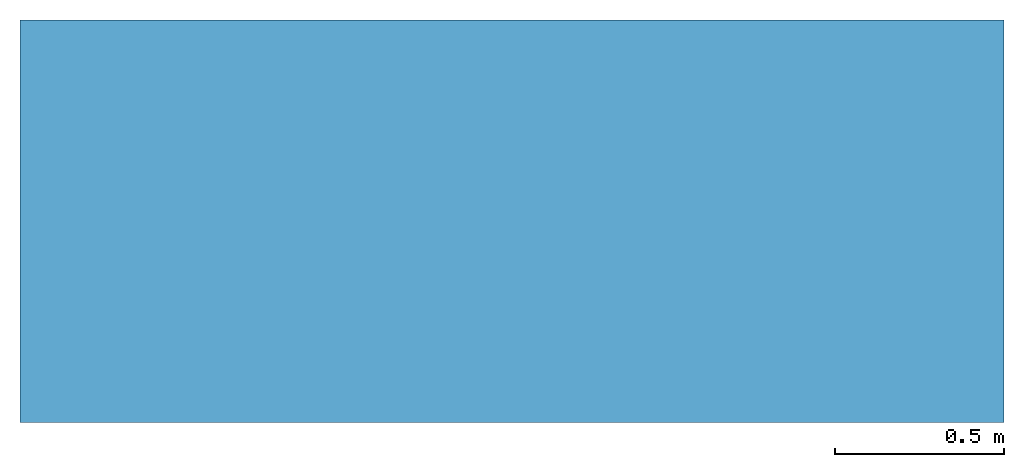
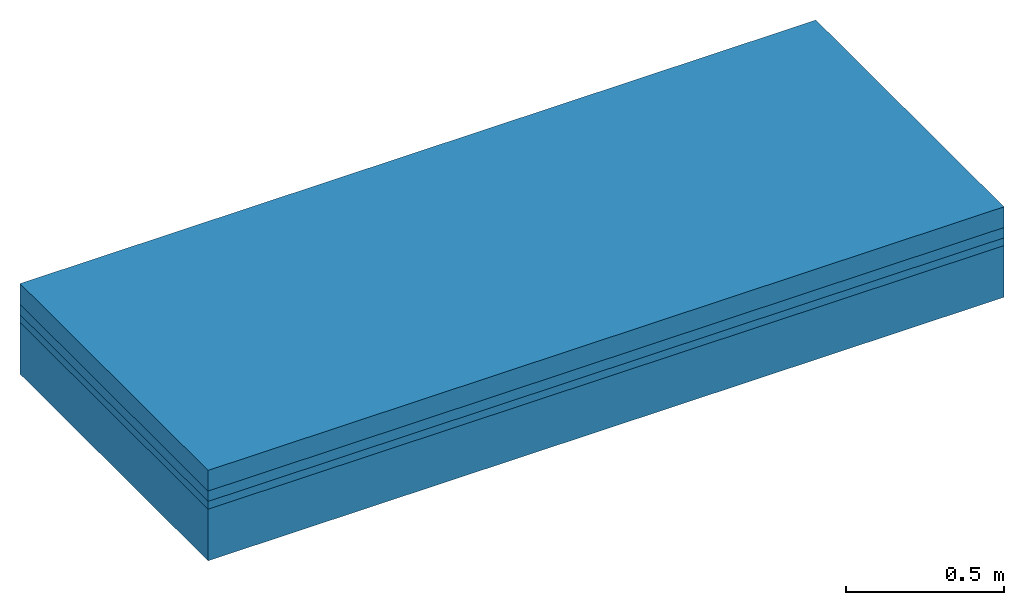
# One storey: 4 building element parts, 1 element without a shape of its own.
"""IFC2X3 building model written with IfcOpenShell, lengths in metres."""

from ifc_helpers import new_model, entity, si_unit, converted_unit, derived_unit, money_unit, direction, frame, origin_with_axes, place, context, subcontext, project, spatial, polyline, outline, extrude, material, type_object, element, aggregate, save


model = new_model("IFC2X3")

# Units and contexts
model_context = context("Model", 3, precision=1e-05, world=origin_with_axes(), true_north=direction((0.309016994375, 0.951056516295)))
body_context = subcontext(model_context, "Body", "Model", "MODEL_VIEW")
ifc_project = project(units=[si_unit("LENGTHUNIT", "METRE"), si_unit("AREAUNIT", "SQUARE_METRE"), si_unit("VOLUMEUNIT", "CUBIC_METRE"), converted_unit("PLANEANGLEUNIT", "DEGREE", entity("IfcPlaneAngleMeasure", 0.0174532925199), si_unit("PLANEANGLEUNIT", "RADIAN"), dimensions=[0, 0, 0, 0, 0, 0, 0]), si_unit("SOLIDANGLEUNIT", "STERADIAN"), money_unit("EUR"), si_unit("TIMEUNIT", "SECOND"), si_unit("MASSUNIT", "GRAM", prefix="KILO"), si_unit("THERMODYNAMICTEMPERATUREUNIT", "DEGREE_CELSIUS"), si_unit("LUMINOUSINTENSITYUNIT", "LUMEN"), si_unit("ENERGYUNIT", "JOULE", prefix="MEGA"), derived_unit("THERMALCONDUCTANCEUNIT", [(si_unit("POWERUNIT", "WATT"), 1), (si_unit("LENGTHUNIT", "METRE"), -1), (si_unit("THERMODYNAMICTEMPERATUREUNIT", "KELVIN"), -1)]), derived_unit("SPECIFICHEATCAPACITYUNIT", [(si_unit("ENERGYUNIT", "JOULE"), 1), (si_unit("MASSUNIT", "GRAM", prefix="KILO"), -1), (si_unit("THERMODYNAMICTEMPERATUREUNIT", "KELVIN"), -1)]), derived_unit("MASSDENSITYUNIT", [(si_unit("MASSUNIT", "GRAM", prefix="KILO"), 1), (si_unit("VOLUMEUNIT", "CUBIC_METRE"), -1)])], contexts=[model_context])

# Site, building, storey
site_placement = place(None, origin_with_axes())
site = spatial("IfcSite", under=ifc_project, at=site_placement, CompositionType="ELEMENT")
building_placement = place(site_placement, origin_with_axes())
building = spatial("IfcBuilding", under=site, at=building_placement, CompositionType="ELEMENT")
storey_placement = place(building_placement, frame((0.0, 0.0, 2.88), z_axis=(0.0, 0.0, 1.0), x_axis=(1.0, 0.0, 0.0)))
storey = spatial("IfcBuildingStorey", under=building, at=storey_placement, Name="1.Obergeschoss", CompositionType="ELEMENT", Elevation=2.88)

# Slab, building element parts
slab_type = type_object("IfcSlabType", Name="302_Decke allgemein (LOD200) 350", PredefinedType="FLOOR")
slab_placement = place(storey_placement, frame((4.43012829992, 3.40402879337, -0.15), z_axis=(0.0, 0.0, 1.0), x_axis=(1.0, 0.0, 0.0)))
slab = element("IfcSlab", 1, at=slab_placement, inside=storey, type_object=slab_type, PredefinedType="FLOOR")
ifc_material_1 = material(Name="Beton, Stahlbeton Decke")
building_element_part_1_placement = place(slab_placement, origin_with_axes())
building_element_part_1 = element("IfcBuildingElementPart", 2, at=building_element_part_1_placement, material=ifc_material_1, Name="Beton, Stahlbeton Decke", context=body_context, shape_type="SweptSolid", body=[
    extrude(outline(polyline([(0.0, 0.0), (2.91326862204, 0.0), (2.91326862204, 1.19237758183), (0.0, 1.19237758183), (0.0, 0.0)])), frame((0.0, 0.0, -0.2), z_axis=(0.0, 0.0, 1.0), x_axis=(1.0, 0.0, 0.0)), (0.0, 0.0, 1.0), 0.2),
])
ifc_material_2 = material(Name="Boden, Sand")
building_element_part_2_placement = place(slab_placement, origin_with_axes())
building_element_part_2 = element("IfcBuildingElementPart", 3, at=building_element_part_2_placement, material=ifc_material_2, Name="Boden, Sand", context=body_context, shape_type="SweptSolid", body=[
    extrude(outline(polyline([(0.0, 0.0), (2.91326862204, 0.0), (2.91326862204, 1.19237758183), (0.0, 1.19237758183), (0.0, 0.0)])), origin_with_axes(), (0.0, 0.0, 1.0), 0.03),
])
ifc_material_3 = material()
building_element_part_3_placement = place(slab_placement, origin_with_axes())
building_element_part_3 = element("IfcBuildingElementPart", 4, at=building_element_part_3_placement, material=ifc_material_3, context=body_context, shape_type="SweptSolid", body=[
    extrude(outline(polyline([(0.0, 0.0), (2.91326862204, 0.0), (2.91326862204, 1.19237758183), (0.0, 1.19237758183), (0.0, 0.0)])), frame((0.0, 0.0, 0.03), z_axis=(0.0, 0.0, 1.0), x_axis=(1.0, 0.0, 0.0)), (0.0, 0.0, 1.0), 0.04),
])
ifc_material_4 = material(Name="Estrich")
building_element_part_4_placement = place(slab_placement, origin_with_axes())
building_element_part_4 = element("IfcBuildingElementPart", 5, at=building_element_part_4_placement, material=ifc_material_4, Name="Estrich", context=body_context, shape_type="SweptSolid", body=[
    extrude(outline(polyline([(0.0, 0.0), (2.91326862204, 0.0), (2.91326862204, 1.19237758183), (0.0, 1.19237758183), (0.0, 0.0)])), frame((0.0, 0.0, 0.07), z_axis=(0.0, 0.0, 1.0), x_axis=(1.0, 0.0, 0.0)), (0.0, 0.0, 1.0), 0.08),
])
aggregate(slab, [building_element_part_1, building_element_part_2, building_element_part_3, building_element_part_4])

save(model, "model.ifc")
